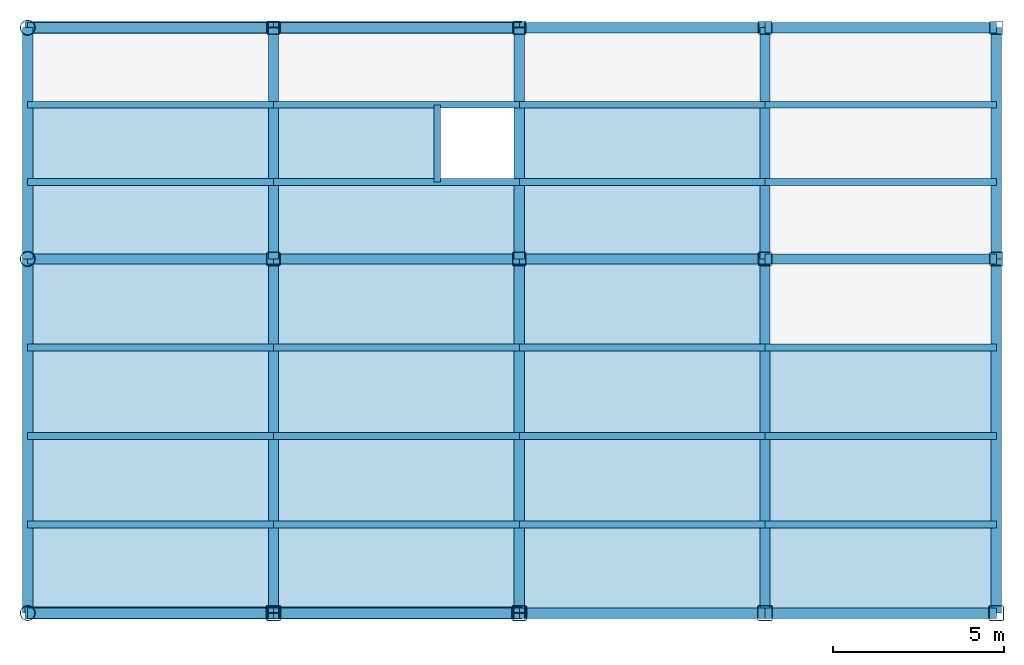
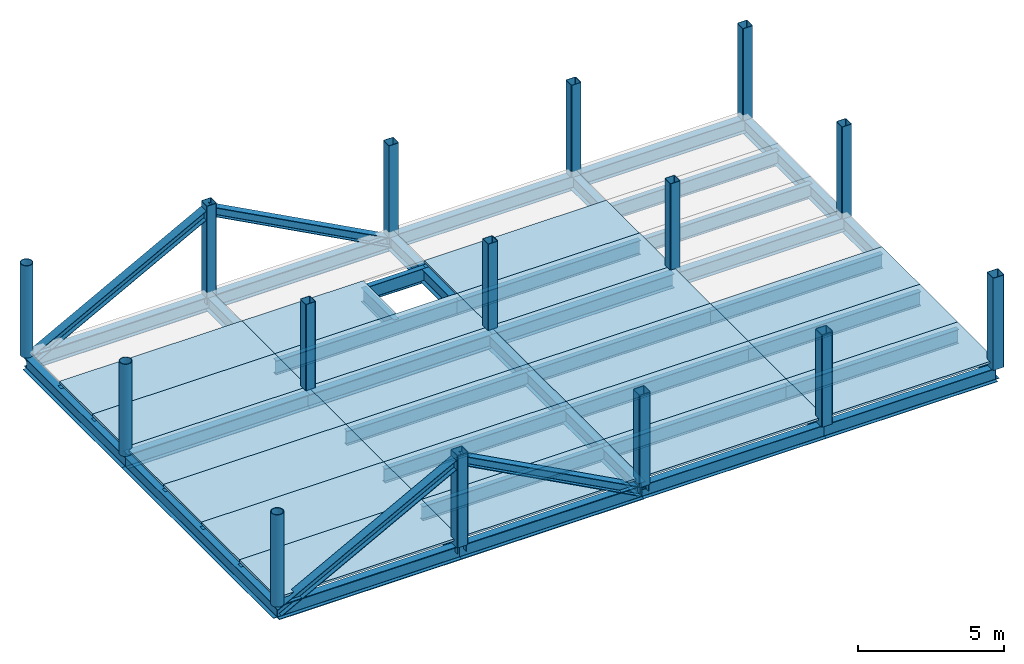
# One storey, part 1 of 2: 43 beams, 21 slabs, 19 columns, 4 members.
"""IFC2X3 building model written with IfcOpenShell, lengths in millimetres."""

from ifc_helpers import new_model, si_unit, frame, origin_with_axes, origin_2d_with_axis, place, context, subcontext, project, spatial, polyline, hollow_rectangle, hollow_circle, i_section, outline, extrude, material, layer, layer_set, layer_usage, type_object, element, save


model = new_model("IFC2X3")

# Units and contexts
model_context = context("Model", 3, precision=1e-05, world=origin_with_axes())
body_context = subcontext(model_context, "Body", "Model", "MODEL_VIEW")
ifc_project = project(units=[si_unit("LENGTHUNIT", "METRE", prefix="MILLI"), si_unit("AREAUNIT", "SQUARE_METRE"), si_unit("VOLUMEUNIT", "CUBIC_METRE"), si_unit("MASSUNIT", "GRAM", prefix="KILO"), si_unit("TIMEUNIT", "SECOND"), si_unit("PLANEANGLEUNIT", "RADIAN"), si_unit("SOLIDANGLEUNIT", "STERADIAN"), si_unit("THERMODYNAMICTEMPERATUREUNIT", "DEGREE_CELSIUS"), si_unit("LUMINOUSINTENSITYUNIT", "LUMEN")], contexts=[model_context])

# Site, building, storey
site_placement = place(None, origin_with_axes())
site = spatial("IfcSite", under=ifc_project, at=site_placement, CompositionType="ELEMENT")
building_placement = place(site_placement, origin_with_axes())
building = spatial("IfcBuilding", under=site, at=building_placement, Name="Undefined", CompositionType="ELEMENT")
storey_placement = place(building_placement, origin_with_axes())
storey = spatial("IfcBuildingStorey", under=building, at=storey_placement, Name="2", CompositionType="ELEMENT", Elevation=0.0)

# Columns
ifc_material_1 = material(Name="STEEL/SN490")
column_type_1 = type_object("IfcColumnType", PredefinedType="NOTDEFINED")
for number, where, z_axis, x_axis, name in (
    (1, (21600.0, 17150.0, 3850.0), (0.0, 0.0, 1.0), (-1.0, 0.0, 0.0), "2AC3G2"),
    (2, (28800.0, 17150.0, 3850.0), (0.0, 0.0, 1.0), (-1.0, 0.0, 0.0), "2VC4G2"),
    (3, (28800.0, 0.0, 3850.0), (0.0, 0.0, 1.0), (-1.0, 0.0, 0.0), "2VA4G2"),
    (4, (21600.0, 0.0, 3850.0), (0.0, 0.0, 1.0), (-1.0, 0.0, 0.0), "2AA3G2"),
):
    element("IfcColumn", number, at=place(storey_placement, frame(where, z_axis=z_axis, x_axis=x_axis)), inside=storey, type_object=column_type_1, material=ifc_material_1, Name=name, context=body_context, shape_type="SweptSolid", body=[
        extrude(i_section(OverallWidth=350.0, OverallDepth=350.0, WebThickness=12.0, FlangeThickness=19.0, FilletRadius=13.0, at=origin_2d_with_axis()), frame((0.0, 0.0, 3850.0), z_axis=(0.0, 0.0, -1.0), x_axis=(0.0, 1.0, 0.0)), (0.0, 0.0, 1.0), 3850.0),
    ])
ifc_material_2 = material(Name="STEEL/SM490")
column_type_2 = type_object("IfcColumnType", PredefinedType="NOTDEFINED")
for number, where, z_axis, x_axis, name in (
    (5, (14400.0, 0.0, 4150.0), (0.0, 0.0, 1.0), (0.0, 1.0, 0.0), "2CA3"),
    (6, (14400.0, 10375.0, 4150.0), (0.0, 0.0, 1.0), (0.0, 1.0, 0.0), "2CB3"),
    (7, (14400.0, 17150.0, 4150.0), (0.0, 0.0, 1.0), (0.0, 1.0, 0.0), "2CC3"),
):
    element("IfcColumn", number, at=place(storey_placement, frame(where, z_axis=z_axis, x_axis=x_axis)), inside=storey, type_object=column_type_2, material=ifc_material_2, Name=name, context=body_context, shape_type="SweptSolid", body=[
        extrude(hollow_circle(Radius=225.0, WallThickness=22.0, at=origin_2d_with_axis()), frame((0.0, 0.0, 3850.0), z_axis=(0.0, 0.0, -1.0), x_axis=(0.0, 1.0, 0.0)), (0.0, 0.0, 1.0), 3850.0),
    ])
ifc_material_3 = material(Name="STEEL/BCR295")
column_type_3 = type_object("IfcColumnType", PredefinedType="NOTDEFINED")
for number, where, z_axis, x_axis, name in (
    (8, (42775.0, 17150.0, 4150.0), (0.0, 0.0, 1.0), (0.0, 1.0, 0.0), "2CC7"),
    (9, (36000.0, 17150.0, 4150.0), (0.0, 0.0, 1.0), (0.0, 1.0, 0.0), "2CC6"),
    (10, (28800.0, 17150.0, 4150.0), (0.0, 0.0, 1.0), (0.0, 1.0, 0.0), "2CC5"),
    (11, (21600.0, 17150.0, 4150.0), (0.0, 0.0, 1.0), (0.0, 1.0, 0.0), "2CC4"),
    (12, (42775.0, 10375.0, 4150.0), (0.0, 0.0, 1.0), (0.0, 1.0, 0.0), "2CB7"),
    (13, (36000.0, 10375.0, 4150.0), (0.0, 0.0, 1.0), (0.0, 1.0, 0.0), "2CB6"),
    (14, (28800.0, 10375.0, 4150.0), (0.0, 0.0, 1.0), (0.0, 1.0, 0.0), "2CB5"),
    (15, (21600.0, 10375.0, 4150.0), (0.0, 0.0, 1.0), (0.0, 1.0, 0.0), "2CB4"),
):
    element("IfcColumn", number, at=place(storey_placement, frame(where, z_axis=z_axis, x_axis=x_axis)), inside=storey, type_object=column_type_3, material=ifc_material_3, Name=name, context=body_context, shape_type="SweptSolid", body=[
        extrude(hollow_rectangle(XDim=400.0, YDim=400.0, WallThickness=16.0, InnerFilletRadius=24.0, OuterFilletRadius=40.0, at=origin_2d_with_axis()), frame((0.0, 0.0, 3850.0), z_axis=(0.0, 0.0, -1.0), x_axis=(0.0, 1.0, 0.0)), (0.0, 0.0, 1.0), 3850.0),
    ])
column_type_4 = type_object("IfcColumnType", PredefinedType="NOTDEFINED")
for number, where, z_axis, x_axis, name in (
    (16, (42775.0, 0.0, 4150.0), (0.0, 0.0, 1.0), (0.0, 1.0, 0.0), "2CA7"),
    (17, (36000.0, 0.0, 4150.0), (0.0, 0.0, 1.0), (0.0, 1.0, 0.0), "2CA6"),
    (18, (28800.0, 0.0, 4150.0), (0.0, 0.0, 1.0), (0.0, 1.0, 0.0), "2CA5"),
    (19, (21600.0, 0.0, 4150.0), (0.0, 0.0, 1.0), (0.0, 1.0, 0.0), "2CA4"),
):
    element("IfcColumn", number, at=place(storey_placement, frame(where, z_axis=z_axis, x_axis=x_axis)), inside=storey, type_object=column_type_4, material=ifc_material_3, Name=name, context=body_context, shape_type="SweptSolid", body=[
        extrude(hollow_rectangle(XDim=450.0, YDim=450.0, WallThickness=22.0, InnerFilletRadius=33.0, OuterFilletRadius=55.0, at=origin_2d_with_axis()), frame((0.0, 0.0, 3850.0), z_axis=(0.0, 0.0, -1.0), x_axis=(0.0, 1.0, 0.0)), (0.0, 0.0, 1.0), 3850.0),
    ])

# Members
member_type = type_object("IfcMemberType", PredefinedType="NOTDEFINED")
for number, where, z_axis, x_axis, name in (
    (20, (14400.0, 17150.0, 3850.0), (-0.471541511274838, 0.0, 0.881843865513982), (0.881843865513982, 0.0, 0.471541511274838), "2AC3G1"),
    (21, (28800.0, 17150.0, 3850.0), (0.471541511274838, 0.0, 0.881843865513982), (-0.881843865513982, 0.0, 0.471541511274838), "2VC4G1"),
    (22, (28800.0, 0.0, 3850.0), (0.471541511274838, 0.0, 0.881843865513982), (-0.881843865513982, 0.0, 0.471541511274838), "2VA4G1"),
    (23, (14400.0, 0.0, 3850.0), (-0.471541511274838, 0.0, 0.881843865513982), (0.881843865513982, 0.0, 0.471541511274838), "2AA3G1"),
):
    element("IfcMember", number, at=place(storey_placement, frame(where, z_axis=z_axis, x_axis=x_axis)), inside=storey, type_object=member_type, material=ifc_material_1, Name=name, context=body_context, shape_type="SweptSolid", body=[
        extrude(i_section(OverallWidth=350.0, OverallDepth=350.0, WebThickness=12.0, FlangeThickness=19.0, FilletRadius=13.0, at=origin_2d_with_axis()), frame((8164.71065010514, 0.0, 4.53232487657448e-13), z_axis=(-1.0, 0.0, 0.0), x_axis=(0.0, -1.0, 0.0)), (0.0, 0.0, 1.0), 8164.71),
    ])

# Beams
ifc_material_4 = material(Name="STEEL/SS400")
beam_type_1 = type_object("IfcBeamType", PredefinedType="NOTDEFINED")
beam_1_placement = place(storey_placement, frame((26400.0, 12633.3, 3852.0), z_axis=(0.0, 0.0, 1.0), x_axis=(0.0, 1.0, 0.0)))
element("IfcBeam", 24, at=beam_1_placement, inside=storey, type_object=beam_type_1, material=ifc_material_4, Name="2bB4.3", context=body_context, shape_type="SweptSolid", body=[
    extrude(i_section(OverallWidth=199.0, OverallDepth=596.0, WebThickness=10.0, FlangeThickness=15.0, FilletRadius=13.0, at=origin_2d_with_axis()), frame((2258.4, 0.0, 0.0), z_axis=(-1.0, 0.0, 0.0), x_axis=(0.0, -1.0, 0.0)), (0.0, 0.0, 1.0), 2258.4),
])
for number, where, z_axis, x_axis, name in (
    (25, (21600.0, 7781.25, 3852.0), (0.0, 0.0, 1.0), (1.0, 0.0, 0.0), "2bA4.3"),
    (26, (21600.0, 5187.5, 3852.0), (0.0, 0.0, 1.0), (1.0, 0.0, 0.0), "2bA4.2"),
    (27, (21600.0, 2593.75, 3852.0), (0.0, 0.0, 1.0), (1.0, 0.0, 0.0), "2bA4.1"),
    (28, (14400.0, 7781.25, 3852.0), (0.0, 0.0, 1.0), (1.0, 0.0, 0.0), "2bA3.3"),
    (29, (14400.0, 5187.5, 3852.0), (0.0, 0.0, 1.0), (1.0, 0.0, 0.0), "2bA3.2"),
    (30, (14400.0, 2593.75, 3852.0), (0.0, 0.0, 1.0), (1.0, 0.0, 0.0), "2bA3.1"),
):
    element("IfcBeam", number, at=place(storey_placement, frame(where, z_axis=z_axis, x_axis=x_axis)), inside=storey, type_object=beam_type_1, material=ifc_material_4, Name=name, context=body_context, shape_type="SweptSolid", body=[
        extrude(i_section(OverallWidth=199.0, OverallDepth=596.0, WebThickness=10.0, FlangeThickness=15.0, FilletRadius=13.0, at=origin_2d_with_axis()), frame((7200.0, 0.0, 0.0), z_axis=(-1.0, 0.0, 0.0), x_axis=(0.0, -1.0, 0.0)), (0.0, 0.0, 1.0), 7200.0),
    ])
for number, where, z_axis, x_axis, name in (
    (31, (36000.0, 7781.25, 3852.0), (0.0, 0.0, 1.0), (1.0, 0.0, 0.0), "2bA6.3"),
    (32, (36000.0, 5187.5, 3852.0), (0.0, 0.0, 1.0), (1.0, 0.0, 0.0), "2bA6.2"),
    (33, (36000.0, 2593.75, 3852.0), (0.0, 0.0, 1.0), (1.0, 0.0, 0.0), "2bA6.1"),
):
    element("IfcBeam", number, at=place(storey_placement, frame(where, z_axis=z_axis, x_axis=x_axis)), inside=storey, type_object=beam_type_1, material=ifc_material_4, Name=name, context=body_context, shape_type="SweptSolid", body=[
        extrude(i_section(OverallWidth=199.0, OverallDepth=596.0, WebThickness=10.0, FlangeThickness=15.0, FilletRadius=13.0, at=origin_2d_with_axis()), frame((6775.0, 0.0, 0.0), z_axis=(-1.0, 0.0, 0.0), x_axis=(0.0, -1.0, 0.0)), (0.0, 0.0, 1.0), 6775.0),
    ])
for number, where, z_axis, x_axis, name in (
    (34, (28800.0, 7781.25, 3852.0), (0.0, 0.0, 1.0), (1.0, 0.0, 0.0), "2bA5.3"),
    (35, (28800.0, 5187.5, 3852.0), (0.0, 0.0, 1.0), (1.0, 0.0, 0.0), "2bA5.2"),
    (36, (28800.0, 2593.75, 3852.0), (0.0, 0.0, 1.0), (1.0, 0.0, 0.0), "2bA5.1"),
    (37, (21600.0, 14891.7, 3852.0), (0.0, 0.0, 1.0), (1.0, 0.0, 0.0), "2bB4.2"),
    (38, (21600.0, 12633.3, 3852.0), (0.0, 0.0, 1.0), (1.0, 0.0, 0.0), "2bB4.1"),
    (39, (14400.0, 14891.7, 3852.0), (0.0, 0.0, 1.0), (1.0, 0.0, 0.0), "2bB3.2"),
    (40, (14400.0, 12633.3, 3852.0), (0.0, 0.0, 1.0), (1.0, 0.0, 0.0), "2bB3.1"),
):
    element("IfcBeam", number, at=place(storey_placement, frame(where, z_axis=z_axis, x_axis=x_axis)), inside=storey, type_object=beam_type_1, material=ifc_material_4, Name=name, context=body_context, shape_type="SweptSolid", body=[
        extrude(i_section(OverallWidth=199.0, OverallDepth=596.0, WebThickness=10.0, FlangeThickness=15.0, FilletRadius=13.0, at=origin_2d_with_axis()), frame((7200.0, 0.0, 0.0), z_axis=(-1.0, 0.0, 0.0), x_axis=(0.0, -1.0, 0.0)), (0.0, 0.0, 1.0), 7200.0),
    ])
for number, where, z_axis, x_axis, name in (
    (41, (36000.0, 14891.7, 3852.0), (0.0, 0.0, 1.0), (1.0, 0.0, 0.0), "2bB6.2"),
    (42, (36000.0, 12633.3, 3852.0), (0.0, 0.0, 1.0), (1.0, 0.0, 0.0), "2bB6.1"),
):
    element("IfcBeam", number, at=place(storey_placement, frame(where, z_axis=z_axis, x_axis=x_axis)), inside=storey, type_object=beam_type_1, material=ifc_material_4, Name=name, context=body_context, shape_type="SweptSolid", body=[
        extrude(i_section(OverallWidth=199.0, OverallDepth=596.0, WebThickness=10.0, FlangeThickness=15.0, FilletRadius=13.0, at=origin_2d_with_axis()), frame((6775.0, 0.0, 0.0), z_axis=(-1.0, 0.0, 0.0), x_axis=(0.0, -1.0, 0.0)), (0.0, 0.0, 1.0), 6775.0),
    ])
for number, where, z_axis, x_axis, name in (
    (43, (28800.0, 14891.7, 3852.0), (0.0, 0.0, 1.0), (1.0, 0.0, 0.0), "2bB5.2"),
    (44, (28800.0, 12633.3, 3852.0), (0.0, 0.0, 1.0), (1.0, 0.0, 0.0), "2bB5.1"),
):
    element("IfcBeam", number, at=place(storey_placement, frame(where, z_axis=z_axis, x_axis=x_axis)), inside=storey, type_object=beam_type_1, material=ifc_material_4, Name=name, context=body_context, shape_type="SweptSolid", body=[
        extrude(i_section(OverallWidth=199.0, OverallDepth=596.0, WebThickness=10.0, FlangeThickness=15.0, FilletRadius=13.0, at=origin_2d_with_axis()), frame((7200.0, 0.0, 0.0), z_axis=(-1.0, 0.0, 0.0), x_axis=(0.0, -1.0, 0.0)), (0.0, 0.0, 1.0), 7200.0),
    ])
beam_type_2 = type_object("IfcBeamType", PredefinedType="NOTDEFINED")
beam_2_placement = place(storey_placement, frame((42775.0, 10375.0, 3856.0), z_axis=(0.0, 0.0, 1.0), x_axis=(0.0, 1.0, 0.0)))
element("IfcBeam", 45, at=beam_2_placement, inside=storey, type_object=beam_type_2, material=ifc_material_2, Name="2BB7", context=body_context, shape_type="SweptSolid", body=[
    extrude(i_section(OverallWidth=300.0, OverallDepth=588.0, WebThickness=12.0, FlangeThickness=20.0, FilletRadius=13.0, at=origin_2d_with_axis()), frame((6775.0, 0.0, 0.0), z_axis=(-1.0, 0.0, 0.0), x_axis=(0.0, -1.0, 0.0)), (0.0, 0.0, 1.0), 6775.0),
])
beam_3_placement = place(storey_placement, frame((42775.0, 0.0, 3856.0), z_axis=(0.0, 0.0, 1.0), x_axis=(0.0, 1.0, 0.0)))
element("IfcBeam", 46, at=beam_3_placement, inside=storey, type_object=beam_type_2, material=ifc_material_2, Name="2BA7", context=body_context, shape_type="SweptSolid", body=[
    extrude(i_section(OverallWidth=300.0, OverallDepth=588.0, WebThickness=12.0, FlangeThickness=20.0, FilletRadius=13.0, at=origin_2d_with_axis()), frame((10375.0, 0.0, 0.0), z_axis=(-1.0, 0.0, 0.0), x_axis=(0.0, -1.0, 0.0)), (0.0, 0.0, 1.0), 10375.0),
])
beam_4_placement = place(storey_placement, frame((36000.0, 10375.0, 3856.0), z_axis=(0.0, 0.0, 1.0), x_axis=(0.0, 1.0, 0.0)))
element("IfcBeam", 47, at=beam_4_placement, inside=storey, type_object=beam_type_2, material=ifc_material_2, Name="2BB6", context=body_context, shape_type="SweptSolid", body=[
    extrude(i_section(OverallWidth=300.0, OverallDepth=588.0, WebThickness=12.0, FlangeThickness=20.0, FilletRadius=13.0, at=origin_2d_with_axis()), frame((6775.0, 0.0, 0.0), z_axis=(-1.0, 0.0, 0.0), x_axis=(0.0, -1.0, 0.0)), (0.0, 0.0, 1.0), 6775.0),
])
beam_5_placement = place(storey_placement, frame((36000.0, 0.0, 3856.0), z_axis=(0.0, 0.0, 1.0), x_axis=(0.0, 1.0, 0.0)))
element("IfcBeam", 48, at=beam_5_placement, inside=storey, type_object=beam_type_2, material=ifc_material_2, Name="2BA6", context=body_context, shape_type="SweptSolid", body=[
    extrude(i_section(OverallWidth=300.0, OverallDepth=588.0, WebThickness=12.0, FlangeThickness=20.0, FilletRadius=13.0, at=origin_2d_with_axis()), frame((10375.0, 0.0, 0.0), z_axis=(-1.0, 0.0, 0.0), x_axis=(0.0, -1.0, 0.0)), (0.0, 0.0, 1.0), 10375.0),
])
beam_6_placement = place(storey_placement, frame((28800.0, 10375.0, 3856.0), z_axis=(0.0, 0.0, 1.0), x_axis=(0.0, 1.0, 0.0)))
element("IfcBeam", 49, at=beam_6_placement, inside=storey, type_object=beam_type_2, material=ifc_material_2, Name="2BB5", context=body_context, shape_type="SweptSolid", body=[
    extrude(i_section(OverallWidth=300.0, OverallDepth=588.0, WebThickness=12.0, FlangeThickness=20.0, FilletRadius=13.0, at=origin_2d_with_axis()), frame((6775.0, 0.0, 0.0), z_axis=(-1.0, 0.0, 0.0), x_axis=(0.0, -1.0, 0.0)), (0.0, 0.0, 1.0), 6775.0),
])
beam_7_placement = place(storey_placement, frame((28800.0, 0.0, 3856.0), z_axis=(0.0, 0.0, 1.0), x_axis=(0.0, 1.0, 0.0)))
element("IfcBeam", 50, at=beam_7_placement, inside=storey, type_object=beam_type_2, material=ifc_material_2, Name="2BA5", context=body_context, shape_type="SweptSolid", body=[
    extrude(i_section(OverallWidth=300.0, OverallDepth=588.0, WebThickness=12.0, FlangeThickness=20.0, FilletRadius=13.0, at=origin_2d_with_axis()), frame((10375.0, 0.0, 0.0), z_axis=(-1.0, 0.0, 0.0), x_axis=(0.0, -1.0, 0.0)), (0.0, 0.0, 1.0), 10375.0),
])
beam_8_placement = place(storey_placement, frame((21600.0, 10375.0, 3856.0), z_axis=(0.0, 0.0, 1.0), x_axis=(0.0, 1.0, 0.0)))
element("IfcBeam", 51, at=beam_8_placement, inside=storey, type_object=beam_type_2, material=ifc_material_2, Name="2BB4", context=body_context, shape_type="SweptSolid", body=[
    extrude(i_section(OverallWidth=300.0, OverallDepth=588.0, WebThickness=12.0, FlangeThickness=20.0, FilletRadius=13.0, at=origin_2d_with_axis()), frame((6775.0, 0.0, 0.0), z_axis=(-1.0, 0.0, 0.0), x_axis=(0.0, -1.0, 0.0)), (0.0, 0.0, 1.0), 6775.0),
])
beam_9_placement = place(storey_placement, frame((21600.0, 0.0, 3856.0), z_axis=(0.0, 0.0, 1.0), x_axis=(0.0, 1.0, 0.0)))
element("IfcBeam", 52, at=beam_9_placement, inside=storey, type_object=beam_type_2, material=ifc_material_2, Name="2BA4", context=body_context, shape_type="SweptSolid", body=[
    extrude(i_section(OverallWidth=300.0, OverallDepth=588.0, WebThickness=12.0, FlangeThickness=20.0, FilletRadius=13.0, at=origin_2d_with_axis()), frame((10375.0, 0.0, 0.0), z_axis=(-1.0, 0.0, 0.0), x_axis=(0.0, -1.0, 0.0)), (0.0, 0.0, 1.0), 10375.0),
])
beam_10_placement = place(storey_placement, frame((14400.0, 10375.0, 3856.0), z_axis=(0.0, 0.0, 1.0), x_axis=(0.0, 1.0, 0.0)))
element("IfcBeam", 53, at=beam_10_placement, inside=storey, type_object=beam_type_2, material=ifc_material_2, Name="2BB3", context=body_context, shape_type="SweptSolid", body=[
    extrude(i_section(OverallWidth=300.0, OverallDepth=588.0, WebThickness=12.0, FlangeThickness=20.0, FilletRadius=13.0, at=origin_2d_with_axis()), frame((6775.0, 0.0, 0.0), z_axis=(-1.0, 0.0, 0.0), x_axis=(0.0, -1.0, 0.0)), (0.0, 0.0, 1.0), 6775.0),
])
beam_11_placement = place(storey_placement, frame((14400.0, 0.0, 3856.0), z_axis=(0.0, 0.0, 1.0), x_axis=(0.0, 1.0, 0.0)))
element("IfcBeam", 54, at=beam_11_placement, inside=storey, type_object=beam_type_2, material=ifc_material_2, Name="2BA3", context=body_context, shape_type="SweptSolid", body=[
    extrude(i_section(OverallWidth=300.0, OverallDepth=588.0, WebThickness=12.0, FlangeThickness=20.0, FilletRadius=13.0, at=origin_2d_with_axis()), frame((10375.0, 0.0, 0.0), z_axis=(-1.0, 0.0, 0.0), x_axis=(0.0, -1.0, 0.0)), (0.0, 0.0, 1.0), 10375.0),
])
beam_12_placement = place(storey_placement, frame((36000.0, 0.0, 3856.0), z_axis=(0.0, 0.0, 1.0), x_axis=(1.0, 0.0, 0.0)))
element("IfcBeam", 55, at=beam_12_placement, inside=storey, type_object=beam_type_2, material=ifc_material_2, Name="2GA6", context=body_context, shape_type="SweptSolid", body=[
    extrude(i_section(OverallWidth=300.0, OverallDepth=588.0, WebThickness=12.0, FlangeThickness=20.0, FilletRadius=13.0, at=origin_2d_with_axis()), frame((6775.0, 0.0, 0.0), z_axis=(-1.0, 0.0, 0.0), x_axis=(0.0, -1.0, 0.0)), (0.0, 0.0, 1.0), 6775.0),
])
beam_13_placement = place(storey_placement, frame((28800.0, 0.0, 3856.0), z_axis=(0.0, 0.0, 1.0), x_axis=(1.0, 0.0, 0.0)))
element("IfcBeam", 56, at=beam_13_placement, inside=storey, type_object=beam_type_2, material=ifc_material_2, Name="2GA5", context=body_context, shape_type="SweptSolid", body=[
    extrude(i_section(OverallWidth=300.0, OverallDepth=588.0, WebThickness=12.0, FlangeThickness=20.0, FilletRadius=13.0, at=origin_2d_with_axis()), frame((7200.0, 0.0, 0.0), z_axis=(-1.0, 0.0, 0.0), x_axis=(0.0, -1.0, 0.0)), (0.0, 0.0, 1.0), 7200.0),
])
beam_14_placement = place(storey_placement, frame((36000.0, 10375.0, 3856.0), z_axis=(0.0, 0.0, 1.0), x_axis=(1.0, 0.0, 0.0)))
element("IfcBeam", 57, at=beam_14_placement, inside=storey, type_object=beam_type_2, material=ifc_material_2, Name="2GB6", context=body_context, shape_type="SweptSolid", body=[
    extrude(i_section(OverallWidth=300.0, OverallDepth=588.0, WebThickness=12.0, FlangeThickness=20.0, FilletRadius=13.0, at=origin_2d_with_axis()), frame((6775.0, 0.0, 0.0), z_axis=(-1.0, 0.0, 0.0), x_axis=(0.0, -1.0, 0.0)), (0.0, 0.0, 1.0), 6775.0),
])
beam_15_placement = place(storey_placement, frame((28800.0, 10375.0, 3856.0), z_axis=(0.0, 0.0, 1.0), x_axis=(1.0, 0.0, 0.0)))
element("IfcBeam", 58, at=beam_15_placement, inside=storey, type_object=beam_type_2, material=ifc_material_2, Name="2GB5", context=body_context, shape_type="SweptSolid", body=[
    extrude(i_section(OverallWidth=300.0, OverallDepth=588.0, WebThickness=12.0, FlangeThickness=20.0, FilletRadius=13.0, at=origin_2d_with_axis()), frame((7200.0, 0.0, 0.0), z_axis=(-1.0, 0.0, 0.0), x_axis=(0.0, -1.0, 0.0)), (0.0, 0.0, 1.0), 7200.0),
])
beam_16_placement = place(storey_placement, frame((36000.0, 17150.0, 3856.0), z_axis=(0.0, 0.0, 1.0), x_axis=(1.0, 0.0, 0.0)))
element("IfcBeam", 59, at=beam_16_placement, inside=storey, type_object=beam_type_2, material=ifc_material_2, Name="2GC6", context=body_context, shape_type="SweptSolid", body=[
    extrude(i_section(OverallWidth=300.0, OverallDepth=588.0, WebThickness=12.0, FlangeThickness=20.0, FilletRadius=13.0, at=origin_2d_with_axis()), frame((6775.0, 0.0, 0.0), z_axis=(-1.0, 0.0, 0.0), x_axis=(0.0, -1.0, 0.0)), (0.0, 0.0, 1.0), 6775.0),
])
beam_17_placement = place(storey_placement, frame((28800.0, 17150.0, 3856.0), z_axis=(0.0, 0.0, 1.0), x_axis=(1.0, 0.0, 0.0)))
element("IfcBeam", 60, at=beam_17_placement, inside=storey, type_object=beam_type_2, material=ifc_material_2, Name="2GC5", context=body_context, shape_type="SweptSolid", body=[
    extrude(i_section(OverallWidth=300.0, OverallDepth=588.0, WebThickness=12.0, FlangeThickness=20.0, FilletRadius=13.0, at=origin_2d_with_axis()), frame((7200.0, 0.0, 0.0), z_axis=(-1.0, 0.0, 0.0), x_axis=(0.0, -1.0, 0.0)), (0.0, 0.0, 1.0), 7200.0),
])
beam_type_3 = type_object("IfcBeamType", PredefinedType="NOTDEFINED")
for number, where, z_axis, x_axis, name in (
    (61, (21600.0, 0.0, 3850.0), (0.0, 0.0, 1.0), (1.0, 0.0, 0.0), "2GA4"),
    (62, (14400.0, 0.0, 3850.0), (0.0, 0.0, 1.0), (1.0, 0.0, 0.0), "2GA3"),
    (63, (21600.0, 10375.0, 3850.0), (0.0, 0.0, 1.0), (1.0, 0.0, 0.0), "2GB4"),
    (64, (14400.0, 10375.0, 3850.0), (0.0, 0.0, 1.0), (1.0, 0.0, 0.0), "2GB3"),
    (65, (21600.0, 17150.0, 3850.0), (0.0, 0.0, 1.0), (1.0, 0.0, 0.0), "2GC4"),
    (66, (14400.0, 17150.0, 3850.0), (0.0, 0.0, 1.0), (1.0, 0.0, 0.0), "2GC3"),
):
    element("IfcBeam", number, at=place(storey_placement, frame(where, z_axis=z_axis, x_axis=x_axis)), inside=storey, type_object=beam_type_3, material=ifc_material_1, Name=name, context=body_context, shape_type="SweptSolid", body=[
        extrude(i_section(OverallWidth=300.0, OverallDepth=600.0, WebThickness=16.0, FlangeThickness=32.0, FilletRadius=13.0, at=origin_2d_with_axis()), frame((7200.0, 0.0, 0.0), z_axis=(-1.0, 0.0, 0.0), x_axis=(0.0, -1.0, 0.0)), (0.0, 0.0, 1.0), 7200.0),
    ])

# Slabs
ifc_material_5 = material(Name="CONCRETE/FC24")
ifc_layer = layer(ifc_material_5, 90.0)
ifc_layer_set = layer_set([ifc_layer], Name="Floor: Insitu CONCRETE/FC24")
ifc_layer_usage_1 = layer_usage(ifc_layer_set, "AXIS3", "POSITIVE", -45.0)
slab_type_1 = type_object("IfcSlabType", PredefinedType="NOTDEFINED")
slab_1_placement = place(storey_placement, frame((21600.0, 10375.0, 4355.0), z_axis=(0.0, 0.0, 1.0), x_axis=(1.0, 0.0, 0.0)))
element("IfcSlab", 67, at=slab_1_placement, inside=storey, type_object=slab_type_1, material=ifc_layer_usage_1, Name="2SB4.1", PredefinedType="FLOOR", context=body_context, shape_type="SweptSolid", body=[
    extrude(outline(polyline([(0.0, 0.0), (7200.0, 0.0), (7200.0, 2258.30004882813), (0.0, 2258.30004882813), (0.0, 0.0)])), frame((0.0, 0.0, -45.0), z_axis=(0.0, 0.0, 1.0), x_axis=(1.0, 0.0, 0.0)), (0.0, 0.0, 1.0), 90.0),
])
ifc_layer_usage_2 = layer_usage(ifc_layer_set, "AXIS3", "POSITIVE", -45.0)
slab_2_placement = place(storey_placement, frame((28800.0, 12633.3, 4355.0), z_axis=(0.0, 0.0, 1.0), x_axis=(1.0, 0.0, 0.0)))
element("IfcSlab", 68, at=slab_2_placement, inside=storey, type_object=slab_type_1, material=ifc_layer_usage_2, Name="2SB5.2", PredefinedType="FLOOR", context=body_context, shape_type="SweptSolid", body=[
    extrude(outline(polyline([(0.0, 0.0), (7200.0, 0.0), (7200.0, 1341.69995117188), (7200.0, 2258.39990234375), (0.0, 2258.39990234375), (0.0, 1341.69995117188), (0.0, 0.0)])), frame((0.0, 0.0, -45.0), z_axis=(0.0, 0.0, 1.0), x_axis=(1.0, 0.0, 0.0)), (0.0, 0.0, 1.0), 90.0),
])
ifc_layer_usage_3 = layer_usage(ifc_layer_set, "AXIS3", "POSITIVE", -45.0)
slab_3_placement = place(storey_placement, frame((28800.0, 10375.0, 4355.0), z_axis=(0.0, 0.0, 1.0), x_axis=(1.0, 0.0, 0.0)))
element("IfcSlab", 69, at=slab_3_placement, inside=storey, type_object=slab_type_1, material=ifc_layer_usage_3, Name="2SB5.1", PredefinedType="FLOOR", context=body_context, shape_type="SweptSolid", body=[
    extrude(outline(polyline([(0.0, 0.0), (7200.0, 0.0), (7200.0, 2258.30004882813), (0.0, 2258.30004882813), (0.0, 0.0)])), frame((0.0, 0.0, -45.0), z_axis=(0.0, 0.0, 1.0), x_axis=(1.0, 0.0, 0.0)), (0.0, 0.0, 1.0), 90.0),
])
ifc_layer_usage_4 = layer_usage(ifc_layer_set, "AXIS3", "POSITIVE", -45.0)
slab_4_placement = place(storey_placement, frame((21600.0, 12633.3, 4355.0), z_axis=(0.0, 0.0, 1.0), x_axis=(1.0, 0.0, 0.0)))
element("IfcSlab", 70, at=slab_4_placement, inside=storey, type_object=slab_type_1, material=ifc_layer_usage_4, Name="2SB4.2", PredefinedType="FLOOR", context=body_context, shape_type="SweptSolid", body=[
    extrude(outline(polyline([(0.0, 0.0), (4800.0, 0.0), (4800.0, 2258.39990234375), (0.0, 2258.39990234375), (0.0, 1341.69995117188), (0.0, 0.0)])), frame((0.0, 0.0, -45.0), z_axis=(0.0, 0.0, 1.0), x_axis=(1.0, 0.0, 0.0)), (0.0, 0.0, 1.0), 90.0),
])
ifc_layer_usage_5 = layer_usage(ifc_layer_set, "AXIS3", "POSITIVE", -45.0)
slab_5_placement = place(storey_placement, frame((14400.0, 12633.3, 4355.0), z_axis=(0.0, 0.0, 1.0), x_axis=(1.0, 0.0, 0.0)))
element("IfcSlab", 71, at=slab_5_placement, inside=storey, type_object=slab_type_1, material=ifc_layer_usage_5, Name="2SB3.2", PredefinedType="FLOOR", context=body_context, shape_type="SweptSolid", body=[
    extrude(outline(polyline([(0.0, 0.0), (7200.0, 0.0), (7200.0, 1341.69995117188), (7200.0, 2258.39990234375), (0.0, 2258.39990234375), (0.0, 1341.69995117188), (0.0, 0.0)])), frame((0.0, 0.0, -45.0), z_axis=(0.0, 0.0, 1.0), x_axis=(1.0, 0.0, 0.0)), (0.0, 0.0, 1.0), 90.0),
])
ifc_layer_usage_6 = layer_usage(ifc_layer_set, "AXIS3", "POSITIVE", -45.0)
slab_6_placement = place(storey_placement, frame((14400.0, 10375.0, 4355.0), z_axis=(0.0, 0.0, 1.0), x_axis=(1.0, 0.0, 0.0)))
element("IfcSlab", 72, at=slab_6_placement, inside=storey, type_object=slab_type_1, material=ifc_layer_usage_6, Name="2SB3.1", PredefinedType="FLOOR", context=body_context, shape_type="SweptSolid", body=[
    extrude(outline(polyline([(0.0, 0.0), (7200.0, 0.0), (7200.0, 2258.30004882813), (0.0, 2258.30004882813), (0.0, 0.0)])), frame((0.0, 0.0, -45.0), z_axis=(0.0, 0.0, 1.0), x_axis=(1.0, 0.0, 0.0)), (0.0, 0.0, 1.0), 90.0),
])
ifc_layer_usage_7 = layer_usage(ifc_layer_set, "AXIS3", "POSITIVE", -45.0)
slab_type_2 = type_object("IfcSlabType", PredefinedType="NOTDEFINED")
slab_7_placement = place(storey_placement, frame((21600.0, 7781.25, 4355.0), z_axis=(0.0, 0.0, 1.0), x_axis=(1.0, 0.0, 0.0)))
element("IfcSlab", 73, at=slab_7_placement, inside=storey, type_object=slab_type_2, material=ifc_layer_usage_7, Name="2SA4.4", PredefinedType="FLOOR", context=body_context, shape_type="SweptSolid", body=[
    extrude(outline(polyline([(0.0, 0.0), (7200.0, 0.0), (7200.0, 2593.75), (0.0, 2593.75), (0.0, 0.0)])), frame((0.0, 0.0, -45.0), z_axis=(0.0, 0.0, 1.0), x_axis=(1.0, 0.0, 0.0)), (0.0, 0.0, 1.0), 90.0),
])
ifc_layer_usage_8 = layer_usage(ifc_layer_set, "AXIS3", "POSITIVE", -45.0)
slab_8_placement = place(storey_placement, frame((21600.0, 5187.5, 4355.0), z_axis=(0.0, 0.0, 1.0), x_axis=(1.0, 0.0, 0.0)))
element("IfcSlab", 74, at=slab_8_placement, inside=storey, type_object=slab_type_2, material=ifc_layer_usage_8, Name="2SA4.3", PredefinedType="FLOOR", context=body_context, shape_type="SweptSolid", body=[
    extrude(outline(polyline([(0.0, 0.0), (7200.0, 0.0), (7200.0, 1587.5), (7200.0, 2593.75), (0.0, 2593.75), (0.0, 1587.5), (0.0, 0.0)])), frame((0.0, 0.0, -45.0), z_axis=(0.0, 0.0, 1.0), x_axis=(1.0, 0.0, 0.0)), (0.0, 0.0, 1.0), 90.0),
])
ifc_layer_usage_9 = layer_usage(ifc_layer_set, "AXIS3", "POSITIVE", -45.0)
slab_9_placement = place(storey_placement, frame((21600.0, 2593.75, 4355.0), z_axis=(0.0, 0.0, 1.0), x_axis=(1.0, 0.0, 0.0)))
element("IfcSlab", 75, at=slab_9_placement, inside=storey, type_object=slab_type_2, material=ifc_layer_usage_9, Name="2SA4.2", PredefinedType="FLOOR", context=body_context, shape_type="SweptSolid", body=[
    extrude(outline(polyline([(0.0, 0.0), (7200.0, 0.0), (7200.0, 581.25), (7200.0, 2593.75), (0.0, 2593.75), (0.0, 581.25), (0.0, 0.0)])), frame((0.0, 0.0, -45.0), z_axis=(0.0, 0.0, 1.0), x_axis=(1.0, 0.0, 0.0)), (0.0, 0.0, 1.0), 90.0),
])
ifc_layer_usage_10 = layer_usage(ifc_layer_set, "AXIS3", "POSITIVE", -45.0)
slab_10_placement = place(storey_placement, frame((21600.0, 0.0, 4355.0), z_axis=(0.0, 0.0, 1.0), x_axis=(1.0, 0.0, 0.0)))
element("IfcSlab", 76, at=slab_10_placement, inside=storey, type_object=slab_type_2, material=ifc_layer_usage_10, Name="2SA4.1", PredefinedType="FLOOR", context=body_context, shape_type="SweptSolid", body=[
    extrude(outline(polyline([(0.0, 0.0), (7200.0, 0.0), (7200.0, 2593.75), (0.0, 2593.75), (0.0, 0.0)])), frame((0.0, 0.0, -45.0), z_axis=(0.0, 0.0, 1.0), x_axis=(1.0, 0.0, 0.0)), (0.0, 0.0, 1.0), 90.0),
])
ifc_layer_usage_11 = layer_usage(ifc_layer_set, "AXIS3", "POSITIVE", -45.0)
slab_11_placement = place(storey_placement, frame((36000.0, 5187.5, 4355.0), z_axis=(0.0, 0.0, 1.0), x_axis=(1.0, 0.0, 0.0)))
element("IfcSlab", 77, at=slab_11_placement, inside=storey, type_object=slab_type_2, material=ifc_layer_usage_11, Name="2SA6.3", PredefinedType="FLOOR", context=body_context, shape_type="SweptSolid", body=[
    extrude(outline(polyline([(0.0, 0.0), (6775.0, 0.0), (6775.0, 1587.5), (6775.0, 2593.75), (0.0, 2593.75), (0.0, 1587.5), (0.0, 0.0)])), frame((0.0, 0.0, -45.0), z_axis=(0.0, 0.0, 1.0), x_axis=(1.0, 0.0, 0.0)), (0.0, 0.0, 1.0), 90.0),
])
ifc_layer_usage_12 = layer_usage(ifc_layer_set, "AXIS3", "POSITIVE", -45.0)
slab_12_placement = place(storey_placement, frame((36000.0, 2593.75, 4355.0), z_axis=(0.0, 0.0, 1.0), x_axis=(1.0, 0.0, 0.0)))
element("IfcSlab", 78, at=slab_12_placement, inside=storey, type_object=slab_type_2, material=ifc_layer_usage_12, Name="2SA6.2", PredefinedType="FLOOR", context=body_context, shape_type="SweptSolid", body=[
    extrude(outline(polyline([(0.0, 0.0), (6775.0, 0.0), (6775.0, 581.25), (6775.0, 2593.75), (0.0, 2593.75), (0.0, 581.25), (0.0, 0.0)])), frame((0.0, 0.0, -45.0), z_axis=(0.0, 0.0, 1.0), x_axis=(1.0, 0.0, 0.0)), (0.0, 0.0, 1.0), 90.0),
])
ifc_layer_usage_13 = layer_usage(ifc_layer_set, "AXIS3", "POSITIVE", -45.0)
slab_13_placement = place(storey_placement, frame((28800.0, 7781.25, 4355.0), z_axis=(0.0, 0.0, 1.0), x_axis=(1.0, 0.0, 0.0)))
element("IfcSlab", 79, at=slab_13_placement, inside=storey, type_object=slab_type_2, material=ifc_layer_usage_13, Name="2SA5.4", PredefinedType="FLOOR", context=body_context, shape_type="SweptSolid", body=[
    extrude(outline(polyline([(0.0, 0.0), (7200.0, 0.0), (7200.0, 2593.75), (0.0, 2593.75), (0.0, 0.0)])), frame((0.0, 0.0, -45.0), z_axis=(0.0, 0.0, 1.0), x_axis=(1.0, 0.0, 0.0)), (0.0, 0.0, 1.0), 90.0),
])
ifc_layer_usage_14 = layer_usage(ifc_layer_set, "AXIS3", "POSITIVE", -45.0)
slab_14_placement = place(storey_placement, frame((28800.0, 5187.5, 4355.0), z_axis=(0.0, 0.0, 1.0), x_axis=(1.0, 0.0, 0.0)))
element("IfcSlab", 80, at=slab_14_placement, inside=storey, type_object=slab_type_2, material=ifc_layer_usage_14, Name="2SA5.3", PredefinedType="FLOOR", context=body_context, shape_type="SweptSolid", body=[
    extrude(outline(polyline([(0.0, 0.0), (7200.0, 0.0), (7200.0, 1587.5), (7200.0, 2593.75), (0.0, 2593.75), (0.0, 1587.5), (0.0, 0.0)])), frame((0.0, 0.0, -45.0), z_axis=(0.0, 0.0, 1.0), x_axis=(1.0, 0.0, 0.0)), (0.0, 0.0, 1.0), 90.0),
])
ifc_layer_usage_15 = layer_usage(ifc_layer_set, "AXIS3", "POSITIVE", -45.0)
slab_15_placement = place(storey_placement, frame((28800.0, 2593.75, 4355.0), z_axis=(0.0, 0.0, 1.0), x_axis=(1.0, 0.0, 0.0)))
element("IfcSlab", 81, at=slab_15_placement, inside=storey, type_object=slab_type_2, material=ifc_layer_usage_15, Name="2SA5.2", PredefinedType="FLOOR", context=body_context, shape_type="SweptSolid", body=[
    extrude(outline(polyline([(0.0, 0.0), (7200.0, 0.0), (7200.0, 581.25), (7200.0, 2593.75), (0.0, 2593.75), (0.0, 581.25), (0.0, 0.0)])), frame((0.0, 0.0, -45.0), z_axis=(0.0, 0.0, 1.0), x_axis=(1.0, 0.0, 0.0)), (0.0, 0.0, 1.0), 90.0),
])
ifc_layer_usage_16 = layer_usage(ifc_layer_set, "AXIS3", "POSITIVE", -45.0)
slab_16_placement = place(storey_placement, frame((36000.0, 0.0, 4355.0), z_axis=(0.0, 0.0, 1.0), x_axis=(1.0, 0.0, 0.0)))
element("IfcSlab", 82, at=slab_16_placement, inside=storey, type_object=slab_type_2, material=ifc_layer_usage_16, Name="2SA6.1", PredefinedType="FLOOR", context=body_context, shape_type="SweptSolid", body=[
    extrude(outline(polyline([(0.0, 0.0), (6775.0, 0.0), (6775.0, 2593.75), (0.0, 2593.75), (0.0, 0.0)])), frame((0.0, 0.0, -45.0), z_axis=(0.0, 0.0, 1.0), x_axis=(1.0, 0.0, 0.0)), (0.0, 0.0, 1.0), 90.0),
])
ifc_layer_usage_17 = layer_usage(ifc_layer_set, "AXIS3", "POSITIVE", -45.0)
slab_17_placement = place(storey_placement, frame((28800.0, 0.0, 4355.0), z_axis=(0.0, 0.0, 1.0), x_axis=(1.0, 0.0, 0.0)))
element("IfcSlab", 83, at=slab_17_placement, inside=storey, type_object=slab_type_2, material=ifc_layer_usage_17, Name="2SA5.1", PredefinedType="FLOOR", context=body_context, shape_type="SweptSolid", body=[
    extrude(outline(polyline([(0.0, 0.0), (7200.0, 0.0), (7200.0, 2593.75), (0.0, 2593.75), (0.0, 0.0)])), frame((0.0, 0.0, -45.0), z_axis=(0.0, 0.0, 1.0), x_axis=(1.0, 0.0, 0.0)), (0.0, 0.0, 1.0), 90.0),
])
ifc_layer_usage_18 = layer_usage(ifc_layer_set, "AXIS3", "POSITIVE", -45.0)
slab_18_placement = place(storey_placement, frame((14400.0, 7781.25, 4355.0), z_axis=(0.0, 0.0, 1.0), x_axis=(1.0, 0.0, 0.0)))
element("IfcSlab", 84, at=slab_18_placement, inside=storey, type_object=slab_type_2, material=ifc_layer_usage_18, Name="2SA3.4", PredefinedType="FLOOR", context=body_context, shape_type="SweptSolid", body=[
    extrude(outline(polyline([(0.0, 0.0), (7200.0, 0.0), (7200.0, 2593.75), (0.0, 2593.75), (0.0, 0.0)])), frame((0.0, 0.0, -45.0), z_axis=(0.0, 0.0, 1.0), x_axis=(1.0, 0.0, 0.0)), (0.0, 0.0, 1.0), 90.0),
])
ifc_layer_usage_19 = layer_usage(ifc_layer_set, "AXIS3", "POSITIVE", -45.0)
slab_19_placement = place(storey_placement, frame((14400.0, 5187.5, 4355.0), z_axis=(0.0, 0.0, 1.0), x_axis=(1.0, 0.0, 0.0)))
element("IfcSlab", 85, at=slab_19_placement, inside=storey, type_object=slab_type_2, material=ifc_layer_usage_19, Name="2SA3.3", PredefinedType="FLOOR", context=body_context, shape_type="SweptSolid", body=[
    extrude(outline(polyline([(0.0, 0.0), (7200.0, 0.0), (7200.0, 1587.5), (7200.0, 2593.75), (0.0, 2593.75), (0.0, 1587.5), (0.0, 0.0)])), frame((0.0, 0.0, -45.0), z_axis=(0.0, 0.0, 1.0), x_axis=(1.0, 0.0, 0.0)), (0.0, 0.0, 1.0), 90.0),
])
ifc_layer_usage_20 = layer_usage(ifc_layer_set, "AXIS3", "POSITIVE", -45.0)
slab_20_placement = place(storey_placement, frame((14400.0, 2593.75, 4355.0), z_axis=(0.0, 0.0, 1.0), x_axis=(1.0, 0.0, 0.0)))
element("IfcSlab", 86, at=slab_20_placement, inside=storey, type_object=slab_type_2, material=ifc_layer_usage_20, Name="2SA3.2", PredefinedType="FLOOR", context=body_context, shape_type="SweptSolid", body=[
    extrude(outline(polyline([(0.0, 0.0), (7200.0, 0.0), (7200.0, 581.25), (7200.0, 2593.75), (0.0, 2593.75), (0.0, 581.25), (0.0, 0.0)])), frame((0.0, 0.0, -45.0), z_axis=(0.0, 0.0, 1.0), x_axis=(1.0, 0.0, 0.0)), (0.0, 0.0, 1.0), 90.0),
])
ifc_layer_usage_21 = layer_usage(ifc_layer_set, "AXIS3", "POSITIVE", -45.0)
slab_21_placement = place(storey_placement, frame((14400.0, 0.0, 4355.0), z_axis=(0.0, 0.0, 1.0), x_axis=(1.0, 0.0, 0.0)))
element("IfcSlab", 87, at=slab_21_placement, inside=storey, type_object=slab_type_2, material=ifc_layer_usage_21, Name="2SA3.1", PredefinedType="FLOOR", context=body_context, shape_type="SweptSolid", body=[
    extrude(outline(polyline([(0.0, 0.0), (7200.0, 0.0), (7200.0, 2593.75), (0.0, 2593.75), (0.0, 0.0)])), frame((0.0, 0.0, -45.0), z_axis=(0.0, 0.0, 1.0), x_axis=(1.0, 0.0, 0.0)), (0.0, 0.0, 1.0), 90.0),
])

save(model, "model.ifc")
